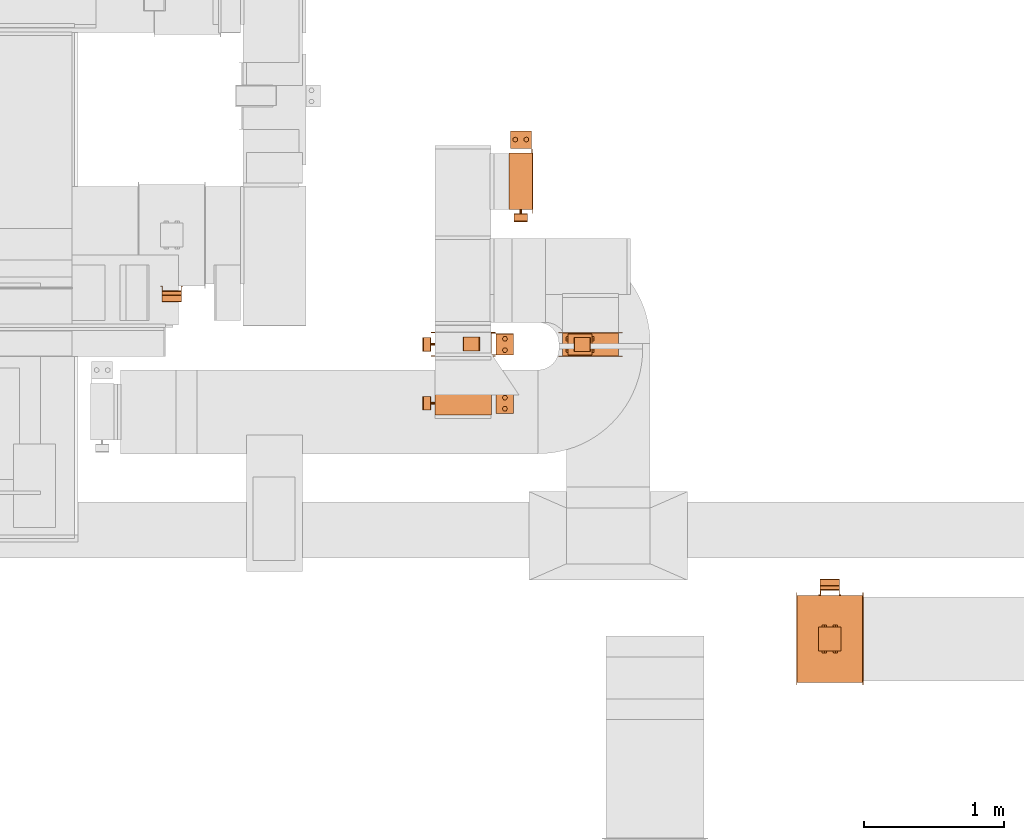
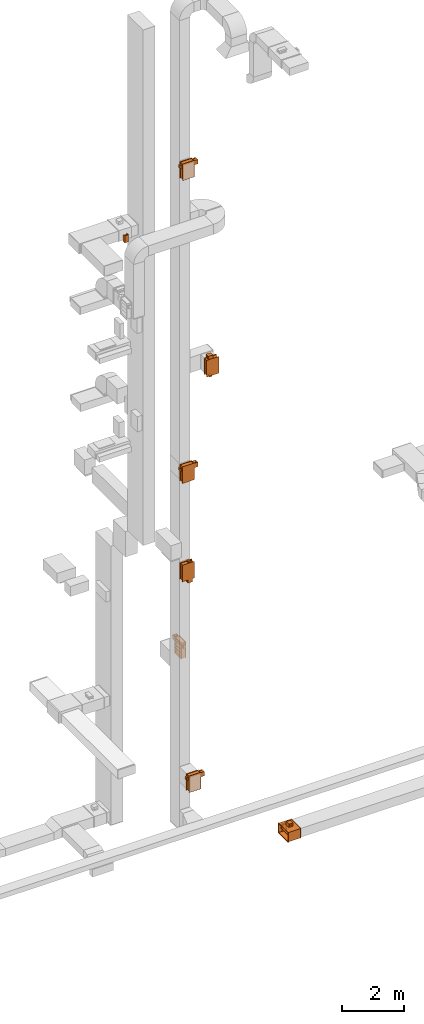
# One storey, part 22 of 25: 15 proxies.
"""IFC2X3 building model written with IfcOpenShell, lengths in millimetres."""

from ifc_helpers import new_model, entity, si_unit, converted_unit, derived_unit, direction, frame, frame_2d, origin, origin_2d_with_axis, place, context, subcontext, project, spatial, polyline, circle_curve, parameter, trimmed, segment, composite_curve, rectangle, circle, hollow_circle, outline, extrude, source, transform, mapped, material, material_list, type_object, type_shapes, element, save


model = new_model("IFC2X3")

# Units and contexts
model_context = context("Model", 3, precision=0.01, world=origin(), true_north=direction((6.12303176911189e-17, 1.0)))
body_context = subcontext(model_context, "Body", "Model", "MODEL_VIEW")
ifc_project = project(units=[si_unit("LENGTHUNIT", "METRE", prefix="MILLI"), si_unit("AREAUNIT", "SQUARE_METRE"), si_unit("VOLUMEUNIT", "CUBIC_METRE"), converted_unit("PLANEANGLEUNIT", "DEGREE", entity("IfcRatioMeasure", 0.0174532925199433), si_unit("PLANEANGLEUNIT", "RADIAN"), dimensions=[0, 0, 0, 0, 0, 0, 0]), si_unit("MASSUNIT", "GRAM", prefix="KILO"), derived_unit("MASSDENSITYUNIT", [(si_unit("MASSUNIT", "GRAM", prefix="KILO"), 1), (si_unit("LENGTHUNIT", "METRE"), -3)]), derived_unit("MOMENTOFINERTIAUNIT", [(si_unit("LENGTHUNIT", "METRE"), 4)]), si_unit("TIMEUNIT", "SECOND"), si_unit("FREQUENCYUNIT", "HERTZ"), si_unit("THERMODYNAMICTEMPERATUREUNIT", "DEGREE_CELSIUS"), derived_unit("THERMALTRANSMITTANCEUNIT", [(si_unit("MASSUNIT", "GRAM", prefix="KILO"), 1), (si_unit("THERMODYNAMICTEMPERATUREUNIT", "KELVIN"), -1), (si_unit("TIMEUNIT", "SECOND"), -3)]), derived_unit("VOLUMETRICFLOWRATEUNIT", [(si_unit("LENGTHUNIT", "METRE"), 3), (si_unit("TIMEUNIT", "SECOND"), -1)]), derived_unit("MASSFLOWRATEUNIT", [(si_unit("MASSUNIT", "GRAM", prefix="KILO"), 1), (si_unit("TIMEUNIT", "SECOND"), -1)]), derived_unit("ROTATIONALFREQUENCYUNIT", [(si_unit("TIMEUNIT", "SECOND"), -1)]), si_unit("ELECTRICCURRENTUNIT", "AMPERE"), si_unit("ELECTRICVOLTAGEUNIT", "VOLT"), si_unit("POWERUNIT", "WATT"), si_unit("FORCEUNIT", "NEWTON", prefix="KILO"), si_unit("ILLUMINANCEUNIT", "LUX"), si_unit("LUMINOUSFLUXUNIT", "LUMEN"), si_unit("LUMINOUSINTENSITYUNIT", "CANDELA"), derived_unit("USERDEFINED", [(si_unit("MASSUNIT", "GRAM", prefix="KILO"), -1), (si_unit("LENGTHUNIT", "METRE"), -2), (si_unit("TIMEUNIT", "SECOND"), 3), (si_unit("LUMINOUSFLUXUNIT", "LUMEN"), 1)]), derived_unit("LINEARVELOCITYUNIT", [(si_unit("LENGTHUNIT", "METRE"), 1), (si_unit("TIMEUNIT", "SECOND"), -1)]), si_unit("PRESSUREUNIT", "PASCAL"), derived_unit("USERDEFINED", [(si_unit("LENGTHUNIT", "METRE"), -2), (si_unit("MASSUNIT", "GRAM", prefix="KILO"), 1), (si_unit("TIMEUNIT", "SECOND"), -2)]), derived_unit("LINEARFORCEUNIT", [(si_unit("MASSUNIT", "GRAM", prefix="KILO"), 1), (si_unit("LENGTHUNIT", "METRE"), 1), (si_unit("TIMEUNIT", "SECOND"), -2), (si_unit("LENGTHUNIT", "METRE"), -1)]), derived_unit("PLANARFORCEUNIT", [(si_unit("MASSUNIT", "GRAM", prefix="KILO"), 1), (si_unit("LENGTHUNIT", "METRE"), 1), (si_unit("TIMEUNIT", "SECOND"), -2), (si_unit("LENGTHUNIT", "METRE"), -2)])], contexts=[model_context])

# Site, building, storey
site_placement = place(None, origin())
site = spatial("IfcSite", under=ifc_project, at=site_placement, CompositionType="ELEMENT")
building_placement = place(site_placement, origin())
building = spatial("IfcBuilding", under=site, at=building_placement, CompositionType="ELEMENT")
storey_placement = place(building_placement, origin())
storey = spatial("IfcBuildingStorey", under=building, at=storey_placement, CompositionType="ELEMENT", Elevation=0.0)

# Proxies
ifc_material_1 = material()
ifc_material_2 = material()
ifc_material_3 = material()
ifc_material_4 = material()
ifc_material_list_1 = material_list([ifc_material_1, ifc_material_2, ifc_material_3, ifc_material_4])
ifc_material_list_2 = material_list([ifc_material_1, ifc_material_1, ifc_material_1, ifc_material_1, ifc_material_1, ifc_material_1, ifc_material_1, ifc_material_1, ifc_material_1, ifc_material_1, ifc_material_1, ifc_material_1, ifc_material_1, ifc_material_1, ifc_material_2, ifc_material_3, ifc_material_4, ifc_material_4, ifc_material_4, ifc_material_4, ifc_material_4, ifc_material_4, ifc_material_4, ifc_material_4, ifc_material_4, ifc_material_4])
building_element_proxy_type_1 = type_object("IfcBuildingElementProxyType", PredefinedType="NOTDEFINED", material=ifc_material_list_2)
shared_shape_1 = source(origin(), body_context, "Body", "SweptSolid", [
    extrude(rectangle(XDim=1.50000000000003, YDim=150.0, at=origin_2d_with_axis()), frame((0.0, 202.25, 157.25), z_axis=(0.0, 0.0, 1.0), x_axis=(0.0, -1.0, 0.0)), (0.0, 0.0, 1.0), 123.000000000001),
    extrude(outline(polyline([(-11.67, -10.5), (-10.17, -10.5), (-10.17, 4.5), (21.85, 4.5), (21.85, 6.01), (-11.67, 6.01), (-11.67, -10.5)])), frame((68.99, 224.83, 157.25), z_axis=(0.0, 0.0, 1.0), x_axis=(0.0, -1.0, 0.0)), (0.0, 0.0, 1.0), 25.0),
    extrude(outline(polyline([(-10.5, -11.67), (6.01, -11.67), (6.01, 21.85), (4.5, 21.85), (4.5, -10.17), (-10.5, -10.17), (-10.5, -11.67)])), frame((-68.99, 224.83, 157.25), z_axis=(0.0, 0.0, 1.0), x_axis=(-1.0, 0.0, 0.0)), (0.0, 0.0, 1.0), 25.0000000000005),
    extrude(outline(polyline([(-11.67, -10.5), (-10.17, -10.5), (-10.17, 4.5), (21.85, 4.5), (21.85, 6.01), (-11.67, 6.01), (-11.67, -10.5)])), frame((68.99, 224.83, 255.25), z_axis=(0.0, 0.0, 1.0), x_axis=(0.0, -1.0, 0.0)), (0.0, 0.0, 1.0), 25.0),
    extrude(outline(polyline([(-9.31, -16.13), (9.31, -16.13), (18.63, 0.0), (9.31, 16.13), (-9.31, 16.13), (-18.63, 0.0), (-9.31, -16.13)])), frame((40.0, 299.0, 307.25), z_axis=(0.0, 0.0, 1.0), x_axis=(0.866025403784569, 0.499999999999775, 0.0)), (0.0, 0.0, 1.0), 10.0),
    extrude(outline(polyline([(-9.26, -16.03), (9.26, -16.03), (18.52, 0.0), (9.26, 16.03), (-9.26, 16.03), (-18.52, 0.0), (-9.26, -16.03)])), frame((-40.0, 299.0, 307.25), z_axis=(0.0, 0.0, 1.0), x_axis=(0.866025403784445, 0.499999999999988, 0.0)), (0.0, 0.0, 1.0), 10.0),
    extrude(hollow_circle(Radius=15.0, WallThickness=6.97527274236894, at=origin_2d_with_axis()), frame((-40.0, 299.0, 305.25), z_axis=(0.0, 0.0, 1.0), x_axis=(-1.0, 0.0, 0.0)), (0.0, 0.0, 1.0), 14.0),
    extrude(hollow_circle(Radius=15.0, WallThickness=7.0, at=origin_2d_with_axis()), frame((40.0, 299.0, 305.25), z_axis=(0.0, 0.0, 1.0), x_axis=(-1.0, 0.0, 0.0)), (0.0, 0.0, 1.0), 14.0),
    extrude(outline(polyline([(-10.5, -11.67), (6.01, -11.67), (6.01, 21.85), (4.5, 21.85), (4.5, -10.17), (-10.5, -10.17), (-10.5, -11.67)])), frame((-68.99, 224.83, 255.25), z_axis=(0.0, 0.0, 1.0), x_axis=(-1.0, 0.0, 0.0)), (0.0, 0.0, 1.0), 25.0),
    extrude(outline(polyline([(-9.31, -16.13), (9.31, -16.13), (18.63, 0.0), (9.31, 16.13), (-9.31, 16.13), (-18.63, 0.0), (-9.31, -16.13)])), frame((40.0, 299.0, 120.25), z_axis=(0.0, 0.0, 1.0), x_axis=(0.866025403784588, 0.499999999999741, 0.0)), (0.0, 0.0, 1.0), 9.99999999999999),
    extrude(outline(polyline([(-9.26, -16.03), (9.26, -16.03), (18.52, 0.0), (9.26, 16.03), (-9.26, 16.03), (-18.52, 0.0), (-9.26, -16.03)])), frame((-40.0, 299.0, 120.25), z_axis=(0.0, 0.0, 1.0), x_axis=(0.866025403784446, 0.499999999999988, 0.0)), (0.0, 0.0, 1.0), 9.99999999999999),
    extrude(hollow_circle(Radius=15.0, WallThickness=6.97527274236894, at=origin_2d_with_axis()), frame((-40.0, 299.0, 118.25), z_axis=(0.0, 0.0, 1.0), x_axis=(-1.0, 0.0, 0.0)), (0.0, 0.0, 1.0), 14.0000000000001),
    extrude(hollow_circle(Radius=15.0, WallThickness=7.0, at=origin_2d_with_axis()), frame((40.0, 299.0, 118.25), z_axis=(0.0, 0.0, 1.0), x_axis=(-1.0, 0.0, 0.0)), (0.0, 0.0, 1.0), 14.0000000000001),
    extrude(rectangle(XDim=125.0, YDim=150.0, at=origin_2d_with_axis()), frame((0.0, 299.0, 132.25), z_axis=(0.0, 0.0, 1.0), x_axis=(0.0, -1.0, 0.0)), (0.0, 0.0, 1.0), 173.0),
    extrude(outline(polyline([(-91.92, -374.77), (-49.5, -374.77), (374.77, 49.5), (374.77, 91.92), (91.92, 374.77), (49.5, 374.77), (-374.77, -49.5), (-374.77, -91.92), (-91.92, -374.77)]), holes=[polyline([(-70.71, -353.55), (-353.55, -70.71), (70.71, 353.55), (353.55, 70.71), (-70.71, -353.55)])]), frame((85.0, 0.0, 0.0), z_axis=(1.0, 0.0, 0.0), x_axis=(0.0, -0.707106781186547, -0.707106781186548)), (0.0, 0.0, 1.0), 1.50000000000001),
    extrude(rectangle(XDim=1.5, YDim=400.0, at=origin_2d_with_axis()), frame((85.75, 0.0, -300.0)), (0.0, 0.0, 1.0), 600.0),
    extrude(outline(polyline([(-10.76, -14.99), (14.24, -14.99), (69.83, -6.99), (69.83, 6.98), (14.24, 15.01), (-10.76, 15.01), (-73.31, 6.98), (-73.31, -6.99), (-10.76, -14.99)])), frame((-1.2, -201.5, 70.92), z_axis=(0.0, 1.0, 0.0), x_axis=(0.707106781186548, 0.0, 0.707106781186548)), (0.0, 0.0, 1.0), 400.0),
    extrude(outline(polyline([(-10.76, -14.99), (14.24, -14.99), (69.83, -6.99), (69.83, 6.98), (14.24, 15.01), (-10.76, 15.01), (-73.31, 6.98), (-73.31, -6.99), (-10.76, -14.99)])), frame((-1.2, -201.5, -73.91), z_axis=(0.0, 1.0, 0.0), x_axis=(0.707106781186548, 0.0, 0.707106781186548)), (0.0, 0.0, 1.0), 400.0),
    extrude(outline(polyline([(-10.76, -14.99), (14.24, -14.99), (69.83, -6.99), (69.83, 6.98), (14.24, 15.01), (-10.76, 15.01), (-73.31, 6.98), (-73.31, -6.99), (-10.76, -14.99)])), frame((-1.2, -201.5, 215.75), z_axis=(0.0, 1.0, 0.0), x_axis=(0.707106781186548, 0.0, 0.707106781186548)), (0.0, 0.0, 1.0), 400.0),
    extrude(outline(polyline([(-10.76, -14.99), (14.24, -14.99), (69.83, -6.99), (69.83, 6.98), (14.24, 15.01), (-10.76, 15.01), (-73.31, 6.98), (-73.31, -6.99), (-10.76, -14.99)])), frame((-1.2, -201.5, -218.75), z_axis=(0.0, 1.0, 0.0), x_axis=(0.707106781186548, 0.0, 0.707106781186548)), (0.0, 0.0, 1.0), 400.0),
    extrude(outline(polyline([(-201.5, -301.5), (201.5, -301.5), (201.5, 301.5), (-201.5, 301.5), (-201.5, -301.5)]), holes=[polyline([(200.0, -300.0), (-200.0, -300.0), (-200.0, 300.0), (200.0, 300.0), (200.0, -300.0)])]), frame((-83.5, 0.0, 0.0), z_axis=(1.0, 0.0, 0.0), x_axis=(0.0, -1.0, 0.0)), (0.0, 0.0, 1.0), 167.0),
    extrude(rectangle(XDim=1.5, YDim=400.000000000054, at=origin_2d_with_axis()), frame((-0.75, 0.0, 291.0), z_axis=(0.0, 0.0, 1.0), x_axis=(-1.0, 0.0, 0.0)), (0.0, 0.0, 1.0), 8.99999999964964),
    extrude(rectangle(XDim=1.5, YDim=399.999999999998, at=origin_2d_with_axis()), frame((-0.75, 0.0, -300.0), z_axis=(0.0, 0.0, 1.0), x_axis=(-1.0, 0.0, 0.0)), (0.0, 0.0, 1.0), 9.00000000035571),
    extrude(outline(polyline([(-330.0, -229.98), (-301.5, -229.98), (301.5, -229.98), (330.0, -229.98), (330.0, 229.98), (301.5, 229.98), (-301.5, 229.98), (-330.0, 229.98), (-330.0, -229.98)]), holes=[polyline([(-300.0, 200.02), (300.0, 200.02), (300.0, -199.98), (-300.0, -199.98), (-300.0, 200.02)])]), frame((83.5, -0.02, 0.0), z_axis=(1.0, 0.0, 0.0), x_axis=(0.0, 0.0, -1.0)), (0.0, 0.0, 1.0), 1.49999999999925),
    extrude(outline(polyline([(-330.0, -229.98), (-301.5, -229.98), (301.5, -229.98), (330.0, -229.98), (330.0, 229.98), (301.5, 229.98), (-301.5, 229.98), (-330.0, 229.98), (-330.0, -229.98)]), holes=[polyline([(-300.0, 200.02), (300.0, 200.02), (300.0, -199.98), (-300.0, -199.98), (-300.0, 200.02)])]), frame((-85.0, -0.02, 0.0), z_axis=(1.0, 0.0, 0.0), x_axis=(0.0, 0.0, -1.0)), (0.0, 0.0, 1.0), 1.50000000000074),
    extrude(circle(Radius=8.0, at=origin_2d_with_axis()), frame((0.0, -230.0, 218.75), z_axis=(0.0, 1.0, 0.0), x_axis=(0.0, 0.0, 1.0)), (0.0, 0.0, 1.0), 28.5),
])
type_shapes(building_element_proxy_type_1, [shared_shape_1])
for number, where, z_axis, x_axis in (
    (1, (31869.89, 10507.42, 24600.0), (0.0, 0.0, 1.0), (0.0, -1.0, 0.0)),
    (2, (31869.89, 10510.0, 12600.0), (0.0, 0.0, 1.0), (0.0, -1.0, 0.0)),
):
    element("IfcBuildingElementProxy", number, at=place(storey_placement, frame(where, z_axis=z_axis, x_axis=x_axis)), inside=storey, type_object=building_element_proxy_type_1, material=ifc_material_list_1, context=body_context, shape_type="MappedRepresentation", body=[
        mapped(shared_shape_1, transform((0.0, 0.0, 0.0), scale=1.0)),
    ])
proxy_1_placement = place(storey_placement, frame((32282.98, 11675.23, 4800.0)))
element("IfcBuildingElementProxy", 3, at=proxy_1_placement, inside=storey, type_object=building_element_proxy_type_1, material=ifc_material_list_1, context=body_context, shape_type="MappedRepresentation", body=[
    mapped(shared_shape_1, transform((0.0, 0.0, 0.0), scale=1.0)),
])
proxy_2_placement = place(storey_placement, frame((31869.89, 10087.24, 600.0), z_axis=(0.0, 0.0, 1.0), x_axis=(0.0, -1.0, 0.0)))
element("IfcBuildingElementProxy", 4, at=proxy_2_placement, inside=storey, type_object=building_element_proxy_type_1, material=ifc_material_list_1, context=body_context, shape_type="MappedRepresentation", body=[
    mapped(shared_shape_1, transform((0.0, 0.0, 0.0), scale=1.0)),
])
ifc_material_list_3 = material_list([ifc_material_1, ifc_material_1, ifc_material_1, ifc_material_1, ifc_material_1, ifc_material_1, ifc_material_1, ifc_material_1, ifc_material_1, ifc_material_1, ifc_material_1, ifc_material_1, ifc_material_1, ifc_material_1, ifc_material_2, ifc_material_3, ifc_material_4, ifc_material_4, ifc_material_4, ifc_material_4, ifc_material_4, ifc_material_4, ifc_material_4, ifc_material_4])
building_element_proxy_type_2 = type_object("IfcBuildingElementProxyType", PredefinedType="NOTDEFINED", material=ifc_material_list_3)
shared_shape_2 = source(origin(), body_context, "Body", "SweptSolid", [
    extrude(rectangle(XDim=1.50000000000003, YDim=150.0, at=origin_2d_with_axis()), frame((0.0, 302.25, 12.75), z_axis=(0.0, 0.0, 1.0), x_axis=(0.0, -1.0, 0.0)), (0.0, 0.0, 1.0), 123.000000000001),
    extrude(outline(polyline([(-11.67, -10.5), (-10.17, -10.5), (-10.17, 4.5), (21.85, 4.5), (21.85, 6.01), (-11.67, 6.01), (-11.67, -10.5)])), frame((68.99, 324.83, 12.75), z_axis=(0.0, 0.0, 1.0), x_axis=(0.0, -1.0, 0.0)), (0.0, 0.0, 1.0), 25.0),
    extrude(outline(polyline([(-10.5, -11.67), (6.01, -11.67), (6.01, 21.85), (4.5, 21.85), (4.5, -10.17), (-10.5, -10.17), (-10.5, -11.67)])), frame((-68.99, 324.83, 12.75), z_axis=(0.0, 0.0, 1.0), x_axis=(-1.0, 0.0, 0.0)), (0.0, 0.0, 1.0), 25.0000000000005),
    extrude(outline(polyline([(-11.67, -10.5), (-10.17, -10.5), (-10.17, 4.5), (21.85, 4.5), (21.85, 6.01), (-11.67, 6.01), (-11.67, -10.5)])), frame((68.99, 324.83, 110.75), z_axis=(0.0, 0.0, 1.0), x_axis=(0.0, -1.0, 0.0)), (0.0, 0.0, 1.0), 25.0),
    extrude(outline(polyline([(-9.31, -16.13), (9.31, -16.13), (18.63, 0.0), (9.31, 16.13), (-9.31, 16.13), (-18.63, 0.0), (-9.31, -16.13)])), frame((40.0, 399.0, 162.75), z_axis=(0.0, 0.0, 1.0), x_axis=(0.866025403784569, 0.499999999999774, 0.0)), (0.0, 0.0, 1.0), 9.99999999999999),
    extrude(outline(polyline([(-9.26, -16.03), (9.26, -16.03), (18.52, 0.0), (9.26, 16.03), (-9.26, 16.03), (-18.52, 0.0), (-9.26, -16.03)])), frame((-40.0, 399.0, 162.75), z_axis=(0.0, 0.0, 1.0), x_axis=(0.866025403784445, 0.499999999999988, 0.0)), (0.0, 0.0, 1.0), 9.99999999999999),
    extrude(hollow_circle(Radius=15.0, WallThickness=6.97527274236894, at=origin_2d_with_axis()), frame((-40.0, 399.0, 160.75), z_axis=(0.0, 0.0, 1.0), x_axis=(-1.0, 0.0, 0.0)), (0.0, 0.0, 1.0), 14.0),
    extrude(hollow_circle(Radius=15.0, WallThickness=7.0, at=origin_2d_with_axis()), frame((40.0, 399.0, 160.75), z_axis=(0.0, 0.0, 1.0), x_axis=(-1.0, 0.0, 0.0)), (0.0, 0.0, 1.0), 14.0),
    extrude(outline(polyline([(-10.5, -11.67), (6.01, -11.67), (6.01, 21.85), (4.5, 21.85), (4.5, -10.17), (-10.5, -10.17), (-10.5, -11.67)])), frame((-68.99, 324.83, 110.75), z_axis=(0.0, 0.0, 1.0), x_axis=(-1.0, 0.0, 0.0)), (0.0, 0.0, 1.0), 25.0),
    extrude(outline(polyline([(-9.31, -16.13), (9.31, -16.13), (18.63, 0.0), (9.31, 16.13), (-9.31, 16.13), (-18.63, 0.0), (-9.31, -16.13)])), frame((40.0, 399.0, -24.25), z_axis=(0.0, 0.0, 1.0), x_axis=(0.866025403784589, 0.499999999999739, 0.0)), (0.0, 0.0, 1.0), 10.0),
    extrude(outline(polyline([(-9.26, -16.03), (9.26, -16.03), (18.52, 0.0), (9.26, 16.03), (-9.26, 16.03), (-18.52, 0.0), (-9.26, -16.03)])), frame((-40.0, 399.0, -24.25), z_axis=(0.0, 0.0, 1.0), x_axis=(0.866025403784447, 0.499999999999985, 0.0)), (0.0, 0.0, 1.0), 9.99999999999999),
    extrude(hollow_circle(Radius=15.0, WallThickness=6.97527274236894, at=origin_2d_with_axis()), frame((-40.0, 399.0, -26.25), z_axis=(0.0, 0.0, 1.0), x_axis=(-1.0, 0.0, 0.0)), (0.0, 0.0, 1.0), 14.0000000000001),
    extrude(hollow_circle(Radius=15.0, WallThickness=7.0, at=origin_2d_with_axis()), frame((40.0, 399.0, -26.25), z_axis=(0.0, 0.0, 1.0), x_axis=(-1.0, 0.0, 0.0)), (0.0, 0.0, 1.0), 14.0000000000001),
    extrude(rectangle(XDim=125.0, YDim=150.0, at=origin_2d_with_axis()), frame((0.0, 399.0, -12.25), z_axis=(0.0, 0.0, 1.0), x_axis=(0.0, -1.0, 0.0)), (0.0, 0.0, 1.0), 173.0),
    extrude(outline(polyline([(49.5, -374.77), (91.92, -374.77), (374.77, -91.92), (374.77, -49.5), (-49.5, 374.77), (-91.92, 374.77), (-374.77, 91.92), (-374.77, 49.5), (49.5, -374.77)]), holes=[polyline([(70.71, -353.55), (-353.55, 70.71), (-70.71, 353.55), (353.55, -70.71), (70.71, -353.55)])]), frame((85.0, 0.0, 0.0), z_axis=(1.0, 0.0, 0.0), x_axis=(0.0, -0.707106781186548, -0.707106781186547)), (0.0, 0.0, 1.0), 1.5),
    extrude(rectangle(XDim=1.5, YDim=600.0, at=origin_2d_with_axis()), frame((85.75, 0.0, -200.0)), (0.0, 0.0, 1.0), 400.0),
    extrude(outline(polyline([(-10.76, -14.99), (14.24, -14.99), (69.83, -6.99), (69.83, 6.98), (14.24, 15.01), (-10.76, 15.01), (-73.31, 6.98), (-73.31, -6.99), (-10.76, -14.99)])), frame((-1.2, -301.5, 71.25), z_axis=(0.0, 1.0, 0.0), x_axis=(0.707106781186548, 0.0, 0.707106781186548)), (0.0, 0.0, 1.0), 600.0),
    extrude(outline(polyline([(-10.76, -14.99), (14.24, -14.99), (69.83, -6.99), (69.83, 6.98), (14.24, 15.01), (-10.76, 15.01), (-73.31, 6.98), (-73.31, -6.99), (-10.76, -14.99)])), frame((-1.2, -301.5, -74.25), z_axis=(0.0, 1.0, 0.0), x_axis=(0.707106781186547, 0.0, 0.707106781186548)), (0.0, 0.0, 1.0), 600.0),
    extrude(outline(polyline([(-301.5, -201.5), (301.5, -201.5), (301.5, 201.5), (-301.5, 201.5), (-301.5, -201.5)]), holes=[polyline([(300.0, -200.0), (-300.0, -200.0), (-300.0, 200.0), (300.0, 200.0), (300.0, -200.0)])]), frame((-83.5, 0.0, 0.0), z_axis=(1.0, 0.0, 0.0), x_axis=(0.0, -1.0, 0.0)), (0.0, 0.0, 1.0), 167.0),
    extrude(rectangle(XDim=1.5, YDim=600.000000000054, at=origin_2d_with_axis()), frame((-0.75, 0.0, 146.5), z_axis=(0.0, 0.0, 1.0), x_axis=(-1.0, 0.0, 0.0)), (0.0, 0.0, 1.0), 53.4999999996496),
    extrude(rectangle(XDim=1.5, YDim=599.999999999997, at=origin_2d_with_axis()), frame((-0.75, 0.0, -200.0), z_axis=(0.0, 0.0, 1.0), x_axis=(-1.0, 0.0, 0.0)), (0.0, 0.0, 1.0), 53.5000000003557),
    extrude(outline(polyline([(-230.0, -329.98), (-201.5, -329.98), (201.5, -329.98), (230.0, -329.98), (230.0, 329.98), (201.5, 329.98), (-201.5, 329.98), (-230.0, 329.98), (-230.0, -329.98)]), holes=[polyline([(-200.0, 300.02), (200.0, 300.02), (200.0, -299.98), (-200.0, -299.98), (-200.0, 300.02)])]), frame((83.5, -0.02, 0.0), z_axis=(1.0, 0.0, 0.0), x_axis=(0.0, 0.0, -1.0)), (0.0, 0.0, 1.0), 1.49999999999925),
    extrude(outline(polyline([(-230.0, -329.98), (-201.5, -329.98), (201.5, -329.98), (230.0, -329.98), (230.0, 329.98), (201.5, 329.98), (-201.5, 329.98), (-230.0, 329.98), (-230.0, -329.98)]), holes=[polyline([(-200.0, 300.02), (200.0, 300.02), (200.0, -299.98), (-200.0, -299.98), (-200.0, 300.02)])]), frame((-85.0, -0.02, 0.0), z_axis=(1.0, 0.0, 0.0), x_axis=(0.0, 0.0, -1.0)), (0.0, 0.0, 1.0), 1.50000000000074),
    extrude(circle(Radius=8.0, at=origin_2d_with_axis()), frame((0.0, -330.0, 74.25), z_axis=(0.0, 1.0, 0.0), x_axis=(0.0, 0.0, 1.0)), (0.0, 0.0, 1.0), 28.5),
])
type_shapes(building_element_proxy_type_2, [shared_shape_2])
proxy_3_placement = place(storey_placement, frame((32781.63, 10507.06, 16500.0), z_axis=(-1.0, 0.0, 0.0), x_axis=(0.0, -1.0, 0.0)))
element("IfcBuildingElementProxy", 5, at=proxy_3_placement, inside=storey, type_object=building_element_proxy_type_2, material=ifc_material_list_3, context=body_context, shape_type="MappedRepresentation", body=[
    mapped(shared_shape_2, transform((0.0, 0.0, 0.0), scale=1.0)),
])
proxy_4_placement = place(storey_placement, frame((31869.89, 10510.38, 8700.0), z_axis=(1.0, 0.0, 0.0), x_axis=(0.0, -1.0, 0.0)))
element("IfcBuildingElementProxy", 6, at=proxy_4_placement, inside=storey, type_object=building_element_proxy_type_2, material=ifc_material_list_1, context=body_context, shape_type="MappedRepresentation", body=[
    mapped(shared_shape_2, transform((0.0, 0.0, 0.0), scale=1.0)),
])
ifc_material_list_4 = material_list([ifc_material_1, ifc_material_1, ifc_material_1, ifc_material_1, ifc_material_1, ifc_material_1, ifc_material_1, ifc_material_1, ifc_material_1, ifc_material_1, ifc_material_1, ifc_material_1, ifc_material_1, ifc_material_1, ifc_material_4, ifc_material_4, ifc_material_4, ifc_material_4, ifc_material_4])
building_element_proxy_type_3 = type_object("IfcBuildingElementProxyType", PredefinedType="NOTDEFINED", material=ifc_material_list_4)
shared_shape_3 = source(origin(), body_context, "Body", "SweptSolid", [
    extrude(rectangle(XDim=1.5, YDim=170.0, at=origin_2d_with_axis()), frame((0.0, -187.75, -62.0), z_axis=(0.0, 0.0, 1.0), x_axis=(0.0, 1.0, 0.0)), (0.0, 0.0, 1.0), 123.000000000001),
    extrude(outline(polyline([(-5.01, -14.16), (-3.51, -14.16), (-3.51, 6.33), (8.51, 6.33), (8.51, 7.84), (-5.01, 7.84), (-5.01, -14.16)])), frame((-72.16, -196.99, -62.0), z_axis=(0.0, 0.0, 1.0), x_axis=(0.0, 1.0, 0.0)), (0.0, 0.0, 1.0), 25.0),
    extrude(outline(polyline([(-13.84, -5.01), (7.67, -5.01), (7.67, 8.51), (6.16, 8.51), (6.16, -3.51), (-13.84, -3.51), (-13.84, -5.01)])), frame((72.33, -196.99, -62.0)), (0.0, 0.0, 1.0), 25.0000000000005),
    extrude(outline(polyline([(-5.01, -14.16), (-3.51, -14.16), (-3.51, 6.33), (8.51, 6.33), (8.51, 7.84), (-5.01, 7.84), (-5.01, -14.16)])), frame((-72.16, -196.99, 36.0), z_axis=(0.0, 0.0, 1.0), x_axis=(0.0, 1.0, 0.0)), (0.0, 0.0, 1.0), 25.0),
    extrude(outline(polyline([(-9.39, -16.09), (8.81, -16.09), (18.35, -0.08), (9.67, 15.92), (-8.96, 16.17), (-18.49, 0.17), (-9.39, -16.09)])), frame((-39.84, -264.5, 88.0), z_axis=(0.0, 0.0, 1.0), x_axis=(-0.859210135894937, -0.511622851693906, 0.0)), (0.0, 0.0, 1.0), 9.99999999999999),
    extrude(outline(polyline([(-9.26, -16.03), (9.26, -16.03), (18.52, 0.0), (9.26, 16.03), (-9.26, 16.03), (-18.52, 0.0), (-9.26, -16.03)])), frame((40.0, -264.5, 88.0), z_axis=(0.0, 0.0, 1.0), x_axis=(-0.86602540378445, -0.499999999999979, 0.0)), (0.0, 0.0, 1.0), 10.0),
    extrude(hollow_circle(Radius=15.0, WallThickness=6.97527274236894, at=origin_2d_with_axis()), frame((40.0, -264.5, 86.0)), (0.0, 0.0, 1.0), 14.0),
    extrude(hollow_circle(Radius=15.0, WallThickness=7.0, at=origin_2d_with_axis()), frame((-40.0, -264.5, 86.0)), (0.0, 0.0, 1.0), 14.0),
    extrude(outline(polyline([(-13.84, -5.01), (7.67, -5.01), (7.67, 8.51), (6.16, 8.51), (6.16, -3.51), (-13.84, -3.51), (-13.84, -5.01)])), frame((72.33, -196.99, 36.0)), (0.0, 0.0, 1.0), 25.0),
    extrude(outline(polyline([(-9.39, -16.09), (8.81, -16.09), (18.35, -0.08), (9.67, 15.92), (-8.96, 16.17), (-18.49, 0.17), (-9.39, -16.09)])), frame((-39.84, -264.5, -98.0), z_axis=(0.0, 0.0, 1.0), x_axis=(-0.859210135895012, -0.511622851693779, 0.0)), (0.0, 0.0, 1.0), 9.99999999999999),
    extrude(outline(polyline([(-9.26, -16.03), (9.26, -16.03), (18.52, 0.0), (9.26, 16.03), (-9.26, 16.03), (-18.52, 0.0), (-9.26, -16.03)])), frame((40.0, -264.5, -98.0), z_axis=(0.0, 0.0, 1.0), x_axis=(-0.866025403784445, -0.49999999999999, 0.0)), (0.0, 0.0, 1.0), 9.99999999999999),
    extrude(hollow_circle(Radius=15.0, WallThickness=6.97527274236894, at=origin_2d_with_axis()), frame((40.0, -264.5, -100.0)), (0.0, 0.0, 1.0), 14.0000000000002),
    extrude(hollow_circle(Radius=15.0, WallThickness=7.0, at=origin_2d_with_axis()), frame((-40.0, -264.5, -100.0)), (0.0, 0.0, 1.0), 14.0000000000002),
    extrude(rectangle(XDim=127.0, YDim=159.999999999992, at=origin_2d_with_axis()), frame((0.0, -265.5, -86.0), z_axis=(0.0, 0.0, 1.0), x_axis=(0.0, 1.0, 0.0)), (0.0, 0.0, 1.0), 171.999999999999),
    extrude(outline(polyline([(-187.0, -312.0), (187.0, -312.0), (187.0, 312.0), (-187.0, 312.0), (-187.0, -312.0)]), holes=[polyline([(175.0, 300.0), (175.0, -300.0), (-175.0, -300.0), (-175.0, 300.0), (175.0, 300.0)])]), frame((-240.0, 0.0, 0.0), z_axis=(1.0, 0.0, 0.0), x_axis=(0.0, -1.0, 0.0)), (0.0, 0.0, 1.0), 480.0),
    extrude(rectangle(XDim=346.0, YDim=24.0000000000003, at=origin_2d_with_axis()), frame((0.0, 0.0, -288.0), z_axis=(0.0, 0.0, 1.0), x_axis=(-1.0, 0.0, 0.0)), (0.0, 0.0, 1.0), 576.000000000017),
    extrude(outline(polyline([(-205.0, -330.0), (205.0, -330.0), (205.0, 330.0), (-205.0, 330.0), (-205.0, -330.0)]), holes=[polyline([(-175.0, -300.0), (-175.0, 300.0), (175.0, 300.0), (175.0, -300.0), (-175.0, -300.0)])]), frame((235.0, 0.0, 0.0), z_axis=(1.0, 0.0, 0.0), x_axis=(0.0, -1.0, 0.0)), (0.0, 0.0, 1.0), 5.00000000000319),
    extrude(outline(polyline([(-205.0, -330.0), (205.0, -330.0), (205.0, 330.0), (-205.0, 330.0), (-205.0, -330.0)]), holes=[polyline([(-175.0, -300.0), (-175.0, 300.0), (175.0, 300.0), (175.0, -300.0), (-175.0, -300.0)])]), frame((-240.0, 0.0, 0.0), z_axis=(1.0, 0.0, 0.0), x_axis=(0.0, -1.0, 0.0)), (0.0, 0.0, 1.0), 4.99999999999991),
    extrude(outline(polyline([(-300.0, -175.0), (300.0, -175.0), (300.0, 175.0), (-300.0, 175.0), (-300.0, -175.0)]), holes=[polyline([(288.0, -163.0), (-288.0, -163.0), (-288.0, 163.0), (288.0, 163.0), (288.0, -163.0)])]), frame((-6.0, 0.0, 0.0), z_axis=(1.0, 0.0, 0.0), x_axis=(0.0, 0.0, -1.0)), (0.0, 0.0, 1.0), 12.0),
])
type_shapes(building_element_proxy_type_3, [shared_shape_3])
proxy_5_placement = place(storey_placement, frame((34495.4, 8400.0, -1250.0), z_axis=(0.0, 1.0, 0.0), x_axis=(1.0, 0.0, 0.0)))
element("IfcBuildingElementProxy", 7, at=proxy_5_placement, inside=storey, type_object=building_element_proxy_type_3, material=ifc_material_list_4, context=body_context, shape_type="MappedRepresentation", body=[
    mapped(shared_shape_3, transform((0.0, 0.0, 0.0), scale=1.0)),
])
ifc_material_5 = material()
ifc_material_list_5 = material_list([ifc_material_5, ifc_material_4])
ifc_material_list_6 = material_list([ifc_material_5, ifc_material_5, ifc_material_4])
building_element_proxy_type_4 = type_object("IfcBuildingElementProxyType", PredefinedType="NOTDEFINED", material=ifc_material_list_6)
shared_shape_4 = source(origin(), body_context, "Body", "SweptSolid", [
    extrude(outline(composite_curve([segment(polyline([(-18.16, -147.54), (18.05, -147.54)]), True, "CONTINUOUS"), segment(trimmed(circle_curve(frame_2d((18.05, -139.09), x_axis=(0.0, -1.0)), 8.44431603721898), [parameter(1.01777749806833e-13)], [parameter(90.0)], True, "PARAMETER"), True, "CONTINUOUS"), segment(polyline([(26.49, -139.09), (26.49, 139.31)]), True, "CONTINUOUS"), segment(trimmed(circle_curve(frame_2d((18.33, 139.31), x_axis=(0.0, -1.0)), 8.15582249386043), [parameter(90.0)], [parameter(180.0)], True, "PARAMETER"), True, "CONTINUOUS"), segment(polyline([(18.33, 147.46), (-18.18, 147.46)]), True, "CONTINUOUS"), segment(trimmed(circle_curve(frame_2d((-18.18, 139.13), x_axis=(0.0, -1.0)), 8.33189596389998), [parameter(180.0)], [parameter(270.0)], True, "PARAMETER"), True, "CONTINUOUS"), segment(polyline([(-26.51, 139.13), (-26.51, -139.19)]), True, "CONTINUOUS"), segment(trimmed(circle_curve(frame_2d((-18.16, -139.19), x_axis=(0.0, -1.0)), 8.35260143157827), [parameter(270.0)], [parameter(4.57999874130747e-13)], True, "PARAMETER"), True, "CONTINUOUS")], self_intersect=False)), frame((-70.0, 12.54, 91.49), z_axis=(1.0, 0.0, 0.0), x_axis=(0.0, 0.0, -1.0)), (0.0, 0.0, 1.0), 139.999999999992),
    extrude(outline(polyline([(-9.17, -80.0), (-4.17, -80.0), (-4.17, -70.0), (15.83, -70.0), (15.83, 70.0), (-4.17, 70.0), (-4.17, 80.0), (-9.17, 80.0), (-9.17, 65.0), (10.83, 65.0), (10.83, -65.0), (-9.17, -65.0), (-9.17, -80.0)])), frame((-70.0, 0.0, 49.17), z_axis=(1.0, 0.0, 0.0), x_axis=(0.0, 0.0, 1.0)), (0.0, 0.0, 1.0), 139.999999999992),
    extrude(outline(polyline([(-14.17, -80.0), (-9.17, -80.0), (-9.17, -70.0), (25.83, -70.0), (25.83, 70.0), (-9.17, 70.0), (-9.17, 80.0), (-14.17, 80.0), (-14.17, 65.0), (20.83, 65.0), (20.83, -65.0), (-14.17, -65.0), (-14.17, -80.0)])), frame((0.0, -135.0, 14.17), z_axis=(0.0, 1.0, 0.0), x_axis=(0.0, 0.0, 1.0)), (0.0, 0.0, 1.0), 270.0),
])
type_shapes(building_element_proxy_type_4, [shared_shape_4])
for number, where, z_axis, x_axis in (
    (8, (29783.91, 10927.62, 22380.0), (0.0, -1.0, 0.0), (1.0, 0.0, 0.0)),
    (9, (34495.4, 8712.0, -1370.0), (0.0, 1.0, 0.0), (-1.0, 0.0, 0.0)),
):
    element("IfcBuildingElementProxy", number, at=place(storey_placement, frame(where, z_axis=z_axis, x_axis=x_axis)), inside=storey, type_object=building_element_proxy_type_4, material=ifc_material_list_5, context=body_context, shape_type="MappedRepresentation", body=[
        mapped(shared_shape_4, transform((0.0, 0.0, 0.0), scale=1.0)),
    ])
building_element_proxy_type_5 = type_object("IfcBuildingElementProxyType", PredefinedType="NOTDEFINED", material=ifc_material_5)
shared_shape_5 = source(origin(), body_context, "Body", "SweptSolid", [
    extrude(outline(composite_curve([segment(trimmed(circle_curve(frame_2d((51.69, 21.66), x_axis=(1.0, 0.0)), 8.35260143157827), [parameter(360.0)], [parameter(89.9999999999998)], True, "PARAMETER"), True, "CONTINUOUS"), segment(polyline([(51.69, 30.01), (-51.63, 30.01)]), True, "CONTINUOUS"), segment(trimmed(circle_curve(frame_2d((-51.63, 21.68), x_axis=(1.0, 0.0)), 8.33189596389998), [parameter(90.0000000000001)], [parameter(180.0)], True, "PARAMETER"), True, "CONTINUOUS"), segment(polyline([(-59.96, 21.68), (-59.96, -21.83)]), True, "CONTINUOUS"), segment(trimmed(circle_curve(frame_2d((-51.81, -21.83), x_axis=(1.0, 0.0)), 8.15582249386043), [parameter(180.0)], [parameter(270.0)], True, "PARAMETER"), True, "CONTINUOUS"), segment(polyline([(-51.81, -29.99), (51.59, -29.99)]), True, "CONTINUOUS"), segment(trimmed(circle_curve(frame_2d((51.59, -21.55), x_axis=(1.0, 0.0)), 8.44431603721898), [parameter(270.0)], [parameter(0.0)], True, "PARAMETER"), True, "CONTINUOUS"), segment(polyline([(60.04, -21.55), (60.04, 21.66)]), True, "CONTINUOUS")], self_intersect=False)), frame((-49.0, 14.96, 29.99), z_axis=(1.0, 0.0, 0.0), x_axis=(0.0, 1.0, 0.0)), (0.0, 0.0, 1.0), 98.0),
])
type_shapes(building_element_proxy_type_5, [shared_shape_5])
for number, where, z_axis, x_axis in (
    (10, (32282.98, 11445.23, 5018.75), (0.0, -1.0, 0.0), (-1.0, 0.0, 0.0)),
    (11, (31639.89, 10087.24, 818.75), (-1.0, 0.0, 0.0), (0.0, 1.0, 0.0)),
    (12, (31944.14, 10510.38, 9030.0), (0.0, 0.0, 1.0), (0.0, 1.0, 0.0)),
    (13, (31639.89, 10507.42, 24818.75), (-1.0, 0.0, 0.0), (0.0, 1.0, 0.0)),
    (14, (31639.89, 10510.0, 12818.75), (-1.0, 0.0, 0.0), (0.0, 1.0, 0.0)),
    (15, (32707.38, 10507.06, 16170.0), (0.0, 0.0, -1.0), (0.0, 1.0, 0.0)),
):
    element("IfcBuildingElementProxy", number, at=place(storey_placement, frame(where, z_axis=z_axis, x_axis=x_axis)), inside=storey, type_object=building_element_proxy_type_5, material=ifc_material_5, context=body_context, shape_type="MappedRepresentation", body=[
        mapped(shared_shape_5, transform((0.0, 0.0, 0.0), scale=1.0)),
    ])

save(model, "model.ifc")
